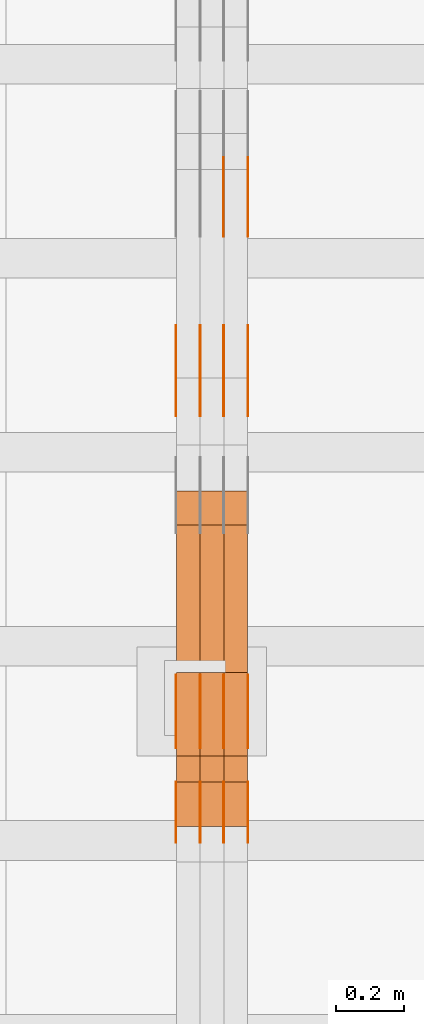
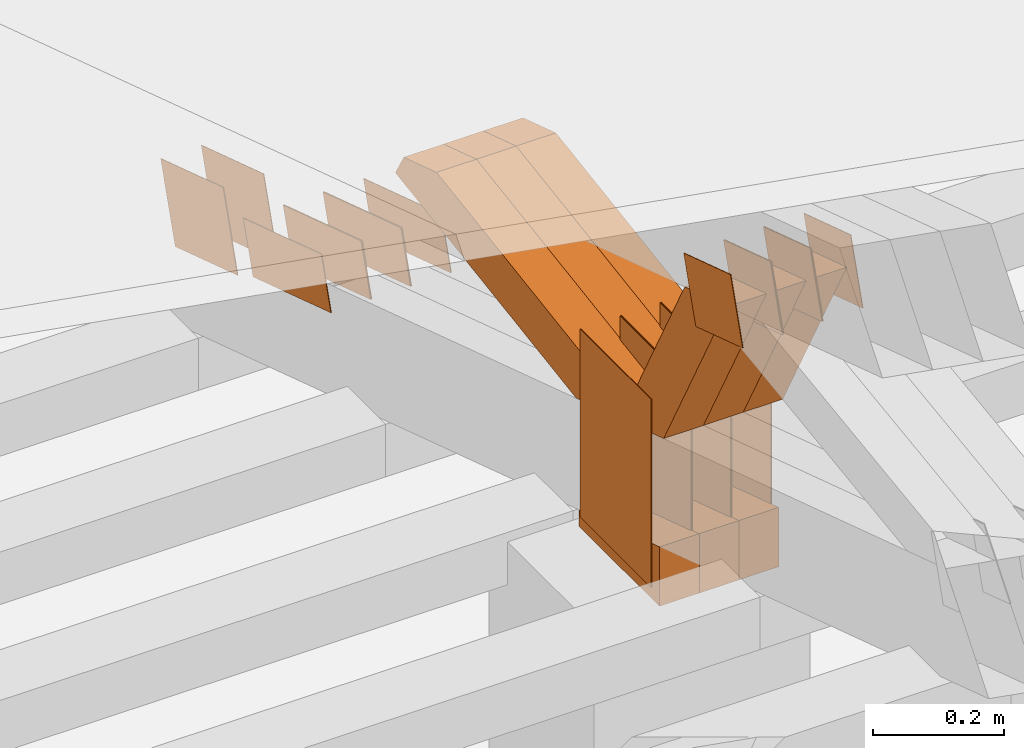
# One storey, part 165 of 385: 29 proxies.
"""IFC2X3 building model written with IfcOpenShell, lengths in millimetres."""

from ifc_helpers import new_model, entity, si_unit, converted_unit, derived_unit, direction, frame, origin, origin_2d_with_axis, place, context, subcontext, project, spatial, polyline, rectangle, outline, extrude, source, transform, mapped, material, type_object, type_shapes, element, save


model = new_model("IFC2X3")

# Units and contexts
model_context = context("Model", 3, precision=0.01, world=origin(), true_north=direction((6.12303176911189e-17, 1.0)))
body_context = subcontext(model_context, "Body", "Model", "MODEL_VIEW")
ifc_project = project(units=[si_unit("LENGTHUNIT", "METRE", prefix="MILLI"), si_unit("AREAUNIT", "SQUARE_METRE"), si_unit("VOLUMEUNIT", "CUBIC_METRE"), converted_unit("PLANEANGLEUNIT", "DEGREE", entity("IfcRatioMeasure", 0.0174532925199433), si_unit("PLANEANGLEUNIT", "RADIAN"), dimensions=[0, 0, 0, 0, 0, 0, 0]), si_unit("MASSUNIT", "GRAM", prefix="KILO"), derived_unit("MASSDENSITYUNIT", [(si_unit("MASSUNIT", "GRAM", prefix="KILO"), 1), (si_unit("LENGTHUNIT", "METRE"), -3)]), si_unit("TIMEUNIT", "SECOND"), si_unit("FREQUENCYUNIT", "HERTZ"), si_unit("THERMODYNAMICTEMPERATUREUNIT", "DEGREE_CELSIUS"), derived_unit("THERMALTRANSMITTANCEUNIT", [(si_unit("MASSUNIT", "GRAM", prefix="KILO"), 1), (si_unit("THERMODYNAMICTEMPERATUREUNIT", "KELVIN"), -1), (si_unit("TIMEUNIT", "SECOND"), -3)]), derived_unit("VOLUMETRICFLOWRATEUNIT", [(si_unit("LENGTHUNIT", "METRE"), 3), (si_unit("TIMEUNIT", "SECOND"), -1)]), si_unit("ELECTRICCURRENTUNIT", "AMPERE"), si_unit("ELECTRICVOLTAGEUNIT", "VOLT"), si_unit("POWERUNIT", "WATT"), si_unit("FORCEUNIT", "NEWTON", prefix="KILO"), si_unit("ILLUMINANCEUNIT", "LUX"), si_unit("LUMINOUSFLUXUNIT", "LUMEN"), si_unit("LUMINOUSINTENSITYUNIT", "CANDELA"), derived_unit("USERDEFINED", [(si_unit("MASSUNIT", "GRAM", prefix="KILO"), -1), (si_unit("LENGTHUNIT", "METRE"), -2), (si_unit("TIMEUNIT", "SECOND"), 3), (si_unit("LUMINOUSFLUXUNIT", "LUMEN"), 1)]), derived_unit("LINEARVELOCITYUNIT", [(si_unit("LENGTHUNIT", "METRE"), 1), (si_unit("TIMEUNIT", "SECOND"), -1)]), si_unit("PRESSUREUNIT", "PASCAL"), derived_unit("USERDEFINED", [(si_unit("LENGTHUNIT", "METRE"), -2), (si_unit("MASSUNIT", "GRAM", prefix="KILO"), 1), (si_unit("TIMEUNIT", "SECOND"), -2)])], contexts=[model_context])

# Site, building, storey
site_placement = place(None, origin())
site = spatial("IfcSite", under=ifc_project, at=site_placement, CompositionType="ELEMENT")
building_placement = place(site_placement, origin())
building = spatial("IfcBuilding", under=site, at=building_placement, CompositionType="ELEMENT")
storey_placement = place(building_placement, origin())
storey = spatial("IfcBuildingStorey", under=building, at=storey_placement, Name="Default", CompositionType="ELEMENT", Elevation=0.0)

# Proxies
ifc_material_1 = material(Name="IfcSurfaceStyle #342422")
building_element_proxy_type_1 = type_object("IfcBuildingElementProxyType", PredefinedType="NOTDEFINED", material=ifc_material_1)
shared_shape_1 = source(origin(), body_context, "Body", "SweptSolid", [
    extrude(outline(polyline([(-125.00031378339, -47.9999612158856), (125.000225258022, -47.9999612158856), (124.999811678525, 47.9999612158856), (-124.999723153156, 47.9999612158856), (-125.00031378339, -47.9999612158856)])), frame((125.000225258022, 48.0000091013474, 0.0), z_axis=(0.0, 0.0, 1.0), x_axis=(-1.0, 0.0, 0.0)), (0.0, 0.0, 1.0), 1.3),
])
type_shapes(building_element_proxy_type_1, [shared_shape_1])
proxy_1_placement = place(building_placement, frame((27386.3, 18456.8597683375, 2657.46691321253), z_axis=(-1.0, 0.0, 0.0), x_axis=(0.0, -0.951056516295124, 0.309016994375039)))
element("IfcBuildingElementProxy", 1, at=proxy_1_placement, inside=storey, type_object=building_element_proxy_type_1, material=ifc_material_1, context=body_context, shape_type="MappedRepresentation", body=[
    mapped(shared_shape_1, transform((0.0, 0.0, 0.0), scale=1.0)),
])
ifc_material_2 = material(Name="IfcSurfaceStyle #342365")
building_element_proxy_type_2 = type_object("IfcBuildingElementProxyType", PredefinedType="NOTDEFINED", material=ifc_material_2)
shared_shape_2 = source(origin(), body_context, "Body", "SweptSolid", [
    extrude(outline(polyline([(-125.00031378339, -47.9999612158856), (125.000225258022, -47.9999612158856), (124.999811678525, 47.9999612158856), (-124.999723153156, 47.9999612158856), (-125.00031378339, -47.9999612158856)])), frame((125.000225258022, 48.0000091013474, 0.0), z_axis=(0.0, 0.0, 1.0), x_axis=(-1.0, 0.0, 0.0)), (0.0, 0.0, 1.0), 1.3),
])
type_shapes(building_element_proxy_type_2, [shared_shape_2])
proxy_2_placement = place(building_placement, frame((27315.0, 18456.8597683375, 2657.46691321253), z_axis=(-1.0, 0.0, 0.0), x_axis=(0.0, -0.951056516295124, 0.309016994375039)))
element("IfcBuildingElementProxy", 2, at=proxy_2_placement, inside=storey, type_object=building_element_proxy_type_2, material=ifc_material_2, context=body_context, shape_type="MappedRepresentation", body=[
    mapped(shared_shape_2, transform((0.0, 0.0, 0.0), scale=1.0)),
])
ifc_material_3 = material(Name="IfcSurfaceStyle #342308")
building_element_proxy_type_3 = type_object("IfcBuildingElementProxyType", PredefinedType="NOTDEFINED", material=ifc_material_3)
shared_shape_3 = source(origin(), body_context, "Body", "SweptSolid", [
    extrude(outline(polyline([(-125.00031378339, -47.9999612158856), (125.000225258022, -47.9999612158856), (124.999811678525, 47.9999612158856), (-124.999723153156, 47.9999612158856), (-125.00031378339, -47.9999612158856)])), frame((125.000225258022, 48.0000091013474, 0.0), z_axis=(0.0, 0.0, 1.0), x_axis=(-1.0, 0.0, 0.0)), (0.0, 0.0, 1.0), 1.3),
])
type_shapes(building_element_proxy_type_3, [shared_shape_3])
proxy_3_placement = place(building_placement, frame((27316.3, 18456.8597683375, 2657.46691321253), z_axis=(-1.0, 0.0, 0.0), x_axis=(0.0, -0.951056516295124, 0.309016994375039)))
element("IfcBuildingElementProxy", 3, at=proxy_3_placement, inside=storey, type_object=building_element_proxy_type_3, material=ifc_material_3, context=body_context, shape_type="MappedRepresentation", body=[
    mapped(shared_shape_3, transform((0.0, 0.0, 0.0), scale=1.0)),
])
ifc_material_4 = material(Name="IfcSurfaceStyle #342251")
building_element_proxy_type_4 = type_object("IfcBuildingElementProxyType", PredefinedType="NOTDEFINED", material=ifc_material_4)
shared_shape_4 = source(origin(), body_context, "Body", "SweptSolid", [
    extrude(outline(polyline([(-125.00031378339, -47.9999612158856), (125.000225258022, -47.9999612158856), (124.999811678525, 47.9999612158856), (-124.999723153156, 47.9999612158856), (-125.00031378339, -47.9999612158856)])), frame((125.000225258022, 48.0000091013474, 0.0), z_axis=(0.0, 0.0, 1.0), x_axis=(-1.0, 0.0, 0.0)), (0.0, 0.0, 1.0), 1.29999999999998),
])
type_shapes(building_element_proxy_type_4, [shared_shape_4])
proxy_4_placement = place(building_placement, frame((27245.0, 18456.8597683375, 2657.46691321253), z_axis=(-1.0, 0.0, 0.0), x_axis=(0.0, -0.951056516295124, 0.309016994375039)))
element("IfcBuildingElementProxy", 4, at=proxy_4_placement, inside=storey, type_object=building_element_proxy_type_4, material=ifc_material_4, context=body_context, shape_type="MappedRepresentation", body=[
    mapped(shared_shape_4, transform((0.0, 0.0, 0.0), scale=1.0)),
])
ifc_material_5 = material(Name="IfcSurfaceStyle #342194")
building_element_proxy_type_5 = type_object("IfcBuildingElementProxyType", PredefinedType="NOTDEFINED", material=ifc_material_5)
shared_shape_5 = source(origin(), body_context, "Body", "SweptSolid", [
    extrude(outline(polyline([(-125.00031378339, -47.9999612158856), (125.000225258022, -47.9999612158856), (124.999811678525, 47.9999612158856), (-124.999723153156, 47.9999612158856), (-125.00031378339, -47.9999612158856)])), frame((125.000225258022, 48.0000091013474, 0.0), z_axis=(0.0, 0.0, 1.0), x_axis=(-1.0, 0.0, 0.0)), (0.0, 0.0, 1.0), 1.29999999999998),
])
type_shapes(building_element_proxy_type_5, [shared_shape_5])
proxy_5_placement = place(building_placement, frame((27246.3, 18456.8597683375, 2657.46691321253), z_axis=(-1.0, 0.0, 0.0), x_axis=(0.0, -0.951056516295124, 0.309016994375039)))
element("IfcBuildingElementProxy", 5, at=proxy_5_placement, inside=storey, type_object=building_element_proxy_type_5, material=ifc_material_5, context=body_context, shape_type="MappedRepresentation", body=[
    mapped(shared_shape_5, transform((0.0, 0.0, 0.0), scale=1.0)),
])
ifc_material_6 = material(Name="IfcSurfaceStyle #342137")
building_element_proxy_type_6 = type_object("IfcBuildingElementProxyType", PredefinedType="NOTDEFINED", material=ifc_material_6)
shared_shape_6 = source(origin(), body_context, "Body", "SweptSolid", [
    extrude(outline(polyline([(-125.00031378339, -47.9999612158856), (125.000225258022, -47.9999612158856), (124.999811678525, 47.9999612158856), (-124.999723153156, 47.9999612158856), (-125.00031378339, -47.9999612158856)])), frame((125.000225258022, 48.0000091013474, 0.0), z_axis=(0.0, 0.0, 1.0), x_axis=(-1.0, 0.0, 0.0)), (0.0, 0.0, 1.0), 1.29999999999998),
])
type_shapes(building_element_proxy_type_6, [shared_shape_6])
proxy_6_placement = place(building_placement, frame((27175.0, 18456.8597683375, 2657.46691321253), z_axis=(-1.0, 0.0, 0.0), x_axis=(0.0, -0.951056516295124, 0.309016994375039)))
element("IfcBuildingElementProxy", 6, at=proxy_6_placement, inside=storey, type_object=building_element_proxy_type_6, material=ifc_material_6, context=body_context, shape_type="MappedRepresentation", body=[
    mapped(shared_shape_6, transform((0.0, 0.0, 0.0), scale=1.0)),
])
ifc_material_7 = material(Name="IfcSurfaceStyle #340712")
building_element_proxy_type_7 = type_object("IfcBuildingElementProxyType", PredefinedType="NOTDEFINED", material=ifc_material_7)
shared_shape_7 = source(origin(), body_context, "Body", "SweptSolid", [
    extrude(outline(polyline([(-99.999796294464, -72.0000050220467), (99.9998768370438, -72.0000050220467), (100.000260677528, 72.0000050220467), (-100.000341220108, 72.0000050220467), (-99.999796294464, -72.0000050220467)])), frame((100.000260677528, 72.0000050220467, 0.0), z_axis=(0.0, 0.0, 1.0), x_axis=(-1.0, 0.0, 0.0)), (0.0, 0.0, 1.0), 1.3),
])
type_shapes(building_element_proxy_type_7, [shared_shape_7])
proxy_7_placement = place(building_placement, frame((27386.3, 18936.3876569477, 2373.90613192527), z_axis=(-1.0, 0.0, 0.0), x_axis=(0.0, -0.951056516295124, 0.309016994375039)))
element("IfcBuildingElementProxy", 7, at=proxy_7_placement, inside=storey, type_object=building_element_proxy_type_7, material=ifc_material_7, context=body_context, shape_type="MappedRepresentation", body=[
    mapped(shared_shape_7, transform((0.0, 0.0, 0.0), scale=1.0)),
])
ifc_material_8 = material(Name="IfcSurfaceStyle #340655")
building_element_proxy_type_8 = type_object("IfcBuildingElementProxyType", PredefinedType="NOTDEFINED", material=ifc_material_8)
shared_shape_8 = source(origin(), body_context, "Body", "SweptSolid", [
    extrude(outline(polyline([(-99.999796294464, -72.0000050220467), (99.9998768370438, -72.0000050220467), (100.000260677528, 72.0000050220467), (-100.000341220108, 72.0000050220467), (-99.999796294464, -72.0000050220467)])), frame((100.000260677528, 72.0000050220467, 0.0), z_axis=(0.0, 0.0, 1.0), x_axis=(-1.0, 0.0, 0.0)), (0.0, 0.0, 1.0), 1.3),
])
type_shapes(building_element_proxy_type_8, [shared_shape_8])
proxy_8_placement = place(building_placement, frame((27315.0, 18936.3876569477, 2373.90613192527), z_axis=(-1.0, 0.0, 0.0), x_axis=(0.0, -0.951056516295124, 0.309016994375039)))
element("IfcBuildingElementProxy", 8, at=proxy_8_placement, inside=storey, type_object=building_element_proxy_type_8, material=ifc_material_8, context=body_context, shape_type="MappedRepresentation", body=[
    mapped(shared_shape_8, transform((0.0, 0.0, 0.0), scale=1.0)),
])
ifc_material_9 = material(Name="IfcSurfaceStyle #340370")
building_element_proxy_type_9 = type_object("IfcBuildingElementProxyType", PredefinedType="NOTDEFINED", material=ifc_material_9)
shared_shape_9 = source(origin(), body_context, "Body", "SweptSolid", [
    extrude(rectangle(XDim=350.0, YDim=215.999999999984, at=origin_2d_with_axis()), frame((175.0, 108.0, 0.0), z_axis=(0.0, 0.0, 1.0), x_axis=(-1.0, 0.0, 0.0)), (0.0, 0.0, 1.0), 1.29999999999999),
])
type_shapes(building_element_proxy_type_9, [shared_shape_9])
proxy_9_placement = place(building_placement, frame((27386.3, 17459.2939453125, 3165.36425781251), z_axis=(-1.0, 0.0, 0.0), x_axis=(0.0, 0.0, -1.0)))
element("IfcBuildingElementProxy", 9, at=proxy_9_placement, inside=storey, type_object=building_element_proxy_type_9, material=ifc_material_9, context=body_context, shape_type="MappedRepresentation", body=[
    mapped(shared_shape_9, transform((0.0, 0.0, 0.0), scale=1.0)),
])
ifc_material_10 = material(Name="IfcSurfaceStyle #340313")
building_element_proxy_type_10 = type_object("IfcBuildingElementProxyType", PredefinedType="NOTDEFINED", material=ifc_material_10)
shared_shape_10 = source(origin(), body_context, "Body", "SweptSolid", [
    extrude(rectangle(XDim=350.0, YDim=215.999999999984, at=origin_2d_with_axis()), frame((175.0, 108.0, 0.0), z_axis=(0.0, 0.0, 1.0), x_axis=(-1.0, 0.0, 0.0)), (0.0, 0.0, 1.0), 1.29999999999999),
])
type_shapes(building_element_proxy_type_10, [shared_shape_10])
proxy_10_placement = place(building_placement, frame((27315.0, 17459.2939453125, 3165.36425781251), z_axis=(-1.0, 0.0, 0.0), x_axis=(0.0, 0.0, -1.0)))
element("IfcBuildingElementProxy", 10, at=proxy_10_placement, inside=storey, type_object=building_element_proxy_type_10, material=ifc_material_10, context=body_context, shape_type="MappedRepresentation", body=[
    mapped(shared_shape_10, transform((0.0, 0.0, 0.0), scale=1.0)),
])
ifc_material_11 = material(Name="IfcSurfaceStyle #340256")
building_element_proxy_type_11 = type_object("IfcBuildingElementProxyType", PredefinedType="NOTDEFINED", material=ifc_material_11)
shared_shape_11 = source(origin(), body_context, "Body", "SweptSolid", [
    extrude(rectangle(XDim=350.0, YDim=215.999999999984, at=origin_2d_with_axis()), frame((175.0, 108.0, 0.0), z_axis=(0.0, 0.0, 1.0), x_axis=(-1.0, 0.0, 0.0)), (0.0, 0.0, 1.0), 1.29999999999999),
])
type_shapes(building_element_proxy_type_11, [shared_shape_11])
proxy_11_placement = place(building_placement, frame((27316.3, 17459.2939453125, 3165.36425781251), z_axis=(-1.0, 0.0, 0.0), x_axis=(0.0, 0.0, -1.0)))
element("IfcBuildingElementProxy", 11, at=proxy_11_placement, inside=storey, type_object=building_element_proxy_type_11, material=ifc_material_11, context=body_context, shape_type="MappedRepresentation", body=[
    mapped(shared_shape_11, transform((0.0, 0.0, 0.0), scale=1.0)),
])
ifc_material_12 = material(Name="IfcSurfaceStyle #340199")
building_element_proxy_type_12 = type_object("IfcBuildingElementProxyType", PredefinedType="NOTDEFINED", material=ifc_material_12)
shared_shape_12 = source(origin(), body_context, "Body", "SweptSolid", [
    extrude(rectangle(XDim=350.0, YDim=215.999999999984, at=origin_2d_with_axis()), frame((175.0, 108.0, 0.0), z_axis=(0.0, 0.0, 1.0), x_axis=(-1.0, 0.0, 0.0)), (0.0, 0.0, 1.0), 1.29999999999998),
])
type_shapes(building_element_proxy_type_12, [shared_shape_12])
proxy_12_placement = place(building_placement, frame((27245.0, 17459.2939453125, 3165.36425781251), z_axis=(-1.0, 0.0, 0.0), x_axis=(0.0, 0.0, -1.0)))
element("IfcBuildingElementProxy", 12, at=proxy_12_placement, inside=storey, type_object=building_element_proxy_type_12, material=ifc_material_12, context=body_context, shape_type="MappedRepresentation", body=[
    mapped(shared_shape_12, transform((0.0, 0.0, 0.0), scale=1.0)),
])
ifc_material_13 = material(Name="IfcSurfaceStyle #340142")
building_element_proxy_type_13 = type_object("IfcBuildingElementProxyType", PredefinedType="NOTDEFINED", material=ifc_material_13)
shared_shape_13 = source(origin(), body_context, "Body", "SweptSolid", [
    extrude(rectangle(XDim=350.0, YDim=215.999999999984, at=origin_2d_with_axis()), frame((175.0, 108.0, 0.0), z_axis=(0.0, 0.0, 1.0), x_axis=(-1.0, 0.0, 0.0)), (0.0, 0.0, 1.0), 1.29999999999998),
])
type_shapes(building_element_proxy_type_13, [shared_shape_13])
proxy_13_placement = place(building_placement, frame((27246.3, 17459.2939453125, 3165.36425781251), z_axis=(-1.0, 0.0, 0.0), x_axis=(0.0, 0.0, -1.0)))
element("IfcBuildingElementProxy", 13, at=proxy_13_placement, inside=storey, type_object=building_element_proxy_type_13, material=ifc_material_13, context=body_context, shape_type="MappedRepresentation", body=[
    mapped(shared_shape_13, transform((0.0, 0.0, 0.0), scale=1.0)),
])
ifc_material_14 = material(Name="IfcSurfaceStyle #340085")
building_element_proxy_type_14 = type_object("IfcBuildingElementProxyType", PredefinedType="NOTDEFINED", material=ifc_material_14)
shared_shape_14 = source(origin(), body_context, "Body", "SweptSolid", [
    extrude(rectangle(XDim=350.0, YDim=215.999999999984, at=origin_2d_with_axis()), frame((175.0, 108.0, 0.0), z_axis=(0.0, 0.0, 1.0), x_axis=(-1.0, 0.0, 0.0)), (0.0, 0.0, 1.0), 1.29999999999998),
])
type_shapes(building_element_proxy_type_14, [shared_shape_14])
proxy_14_placement = place(building_placement, frame((27175.0, 17459.2939453125, 3165.36425781251), z_axis=(-1.0, 0.0, 0.0), x_axis=(0.0, 0.0, -1.0)))
element("IfcBuildingElementProxy", 14, at=proxy_14_placement, inside=storey, type_object=building_element_proxy_type_14, material=ifc_material_14, context=body_context, shape_type="MappedRepresentation", body=[
    mapped(shared_shape_14, transform((0.0, 0.0, 0.0), scale=1.0)),
])
ifc_material_15 = material(Name="IfcSurfaceStyle #336950")
building_element_proxy_type_15 = type_object("IfcBuildingElementProxyType", PredefinedType="NOTDEFINED", material=ifc_material_15)
shared_shape_15 = source(origin(), body_context, "Body", "SweptSolid", [
    extrude(outline(polyline([(-74.9998605591058, -59.9999264677524), (74.999875428623, -59.9999264677524), (74.9998605591068, 59.9999264677524), (-74.9998754286239, 59.9999264677524), (-74.9998605591058, -59.9999264677524)])), frame((75.0002460484325, 60.0000016373508, 0.0), z_axis=(0.0, 0.0, 1.0), x_axis=(-1.0, 0.0, 0.0)), (0.0, 0.0, 1.0), 1.3),
])
type_shapes(building_element_proxy_type_15, [shared_shape_15])
proxy_15_placement = place(building_placement, frame((27386.3, 17107.0599369346, 3383.82825001787), z_axis=(-1.0, 0.0, 0.0), x_axis=(0.0, -0.951056516295154, 0.309016994374948)))
element("IfcBuildingElementProxy", 15, at=proxy_15_placement, inside=storey, type_object=building_element_proxy_type_15, material=ifc_material_15, context=body_context, shape_type="MappedRepresentation", body=[
    mapped(shared_shape_15, transform((0.0, 0.0, 0.0), scale=1.0)),
])
ifc_material_16 = material(Name="IfcSurfaceStyle #336893")
building_element_proxy_type_16 = type_object("IfcBuildingElementProxyType", PredefinedType="NOTDEFINED", material=ifc_material_16)
shared_shape_16 = source(origin(), body_context, "Body", "SweptSolid", [
    extrude(outline(polyline([(-74.9998605591058, -59.9999264677524), (74.999875428623, -59.9999264677524), (74.9998605591068, 59.9999264677524), (-74.9998754286239, 59.9999264677524), (-74.9998605591058, -59.9999264677524)])), frame((75.0002460484325, 60.0000016373508, 0.0), z_axis=(0.0, 0.0, 1.0), x_axis=(-1.0, 0.0, 0.0)), (0.0, 0.0, 1.0), 1.3),
])
type_shapes(building_element_proxy_type_16, [shared_shape_16])
proxy_16_placement = place(building_placement, frame((27315.0, 17107.0599369346, 3383.82825001787), z_axis=(-1.0, 0.0, 0.0), x_axis=(0.0, -0.951056516295154, 0.309016994374948)))
element("IfcBuildingElementProxy", 16, at=proxy_16_placement, inside=storey, type_object=building_element_proxy_type_16, material=ifc_material_16, context=body_context, shape_type="MappedRepresentation", body=[
    mapped(shared_shape_16, transform((0.0, 0.0, 0.0), scale=1.0)),
])
ifc_material_17 = material(Name="IfcSurfaceStyle #336836")
building_element_proxy_type_17 = type_object("IfcBuildingElementProxyType", PredefinedType="NOTDEFINED", material=ifc_material_17)
shared_shape_17 = source(origin(), body_context, "Body", "SweptSolid", [
    extrude(outline(polyline([(-74.9998605591058, -59.9999264677524), (74.999875428623, -59.9999264677524), (74.9998605591068, 59.9999264677524), (-74.9998754286239, 59.9999264677524), (-74.9998605591058, -59.9999264677524)])), frame((75.0002460484325, 60.0000016373508, 0.0), z_axis=(0.0, 0.0, 1.0), x_axis=(-1.0, 0.0, 0.0)), (0.0, 0.0, 1.0), 1.3),
])
type_shapes(building_element_proxy_type_17, [shared_shape_17])
proxy_17_placement = place(building_placement, frame((27316.3, 17107.0599369346, 3383.82825001787), z_axis=(-1.0, 0.0, 0.0), x_axis=(0.0, -0.951056516295154, 0.309016994374948)))
element("IfcBuildingElementProxy", 17, at=proxy_17_placement, inside=storey, type_object=building_element_proxy_type_17, material=ifc_material_17, context=body_context, shape_type="MappedRepresentation", body=[
    mapped(shared_shape_17, transform((0.0, 0.0, 0.0), scale=1.0)),
])
ifc_material_18 = material(Name="IfcSurfaceStyle #336779")
building_element_proxy_type_18 = type_object("IfcBuildingElementProxyType", PredefinedType="NOTDEFINED", material=ifc_material_18)
shared_shape_18 = source(origin(), body_context, "Body", "SweptSolid", [
    extrude(outline(polyline([(-74.9998605591058, -59.9999264677524), (74.999875428623, -59.9999264677524), (74.9998605591068, 59.9999264677524), (-74.9998754286239, 59.9999264677524), (-74.9998605591058, -59.9999264677524)])), frame((75.0002460484325, 60.0000016373508, 0.0), z_axis=(0.0, 0.0, 1.0), x_axis=(-1.0, 0.0, 0.0)), (0.0, 0.0, 1.0), 1.29999999999999),
])
type_shapes(building_element_proxy_type_18, [shared_shape_18])
proxy_18_placement = place(building_placement, frame((27245.0, 17107.0599369346, 3383.82825001787), z_axis=(-1.0, 0.0, 0.0), x_axis=(0.0, -0.951056516295154, 0.309016994374948)))
element("IfcBuildingElementProxy", 18, at=proxy_18_placement, inside=storey, type_object=building_element_proxy_type_18, material=ifc_material_18, context=body_context, shape_type="MappedRepresentation", body=[
    mapped(shared_shape_18, transform((0.0, 0.0, 0.0), scale=1.0)),
])
ifc_material_19 = material(Name="IfcSurfaceStyle #336722")
building_element_proxy_type_19 = type_object("IfcBuildingElementProxyType", PredefinedType="NOTDEFINED", material=ifc_material_19)
shared_shape_19 = source(origin(), body_context, "Body", "SweptSolid", [
    extrude(outline(polyline([(-74.9998605591058, -59.9999264677524), (74.999875428623, -59.9999264677524), (74.9998605591068, 59.9999264677524), (-74.9998754286239, 59.9999264677524), (-74.9998605591058, -59.9999264677524)])), frame((75.0002460484325, 60.0000016373508, 0.0), z_axis=(0.0, 0.0, 1.0), x_axis=(-1.0, 0.0, 0.0)), (0.0, 0.0, 1.0), 1.29999999999999),
])
type_shapes(building_element_proxy_type_19, [shared_shape_19])
proxy_19_placement = place(building_placement, frame((27246.3, 17107.0599369346, 3383.82825001787), z_axis=(-1.0, 0.0, 0.0), x_axis=(0.0, -0.951056516295154, 0.309016994374948)))
element("IfcBuildingElementProxy", 19, at=proxy_19_placement, inside=storey, type_object=building_element_proxy_type_19, material=ifc_material_19, context=body_context, shape_type="MappedRepresentation", body=[
    mapped(shared_shape_19, transform((0.0, 0.0, 0.0), scale=1.0)),
])
ifc_material_20 = material(Name="IfcSurfaceStyle #336665")
building_element_proxy_type_20 = type_object("IfcBuildingElementProxyType", PredefinedType="NOTDEFINED", material=ifc_material_20)
shared_shape_20 = source(origin(), body_context, "Body", "SweptSolid", [
    extrude(outline(polyline([(-74.9998605591058, -59.9999264677524), (74.999875428623, -59.9999264677524), (74.9998605591068, 59.9999264677524), (-74.9998754286239, 59.9999264677524), (-74.9998605591058, -59.9999264677524)])), frame((75.0002460484325, 60.0000016373508, 0.0), z_axis=(0.0, 0.0, 1.0), x_axis=(-1.0, 0.0, 0.0)), (0.0, 0.0, 1.0), 1.29999999999999),
])
type_shapes(building_element_proxy_type_20, [shared_shape_20])
proxy_20_placement = place(building_placement, frame((27175.0, 17107.0599369346, 3383.82825001787), z_axis=(-1.0, 0.0, 0.0), x_axis=(0.0, -0.951056516295154, 0.309016994374948)))
element("IfcBuildingElementProxy", 20, at=proxy_20_placement, inside=storey, type_object=building_element_proxy_type_20, material=ifc_material_20, context=body_context, shape_type="MappedRepresentation", body=[
    mapped(shared_shape_20, transform((0.0, 0.0, 0.0), scale=1.0)),
])
ifc_material_21 = material(Name="IfcSurfaceStyle #328661")
building_element_proxy_type_21 = type_object("IfcBuildingElementProxyType", Name="T1-E1 328659", PredefinedType="NOTDEFINED", material=ifc_material_21)
shared_shape_21 = source(origin(), body_context, "Body", "SweptSolid", [
    extrude(outline(polyline([(4.4675903320374, -122.500000000001), (35.3350219726624, -122.500000000001), (35.3350219726501, 122.500000000001), (-75.1376342773499, 122.500000000001), (4.4675903320374, -122.500000000001)])), frame((35.3350219726624, 122.50000005215, 0.0), z_axis=(0.0, 0.0, 1.0), x_axis=(-1.0, 0.0, 0.0)), (0.0, 0.0, 1.0), 70.0),
])
type_shapes(building_element_proxy_type_21, [shared_shape_21])
proxy_21_placement = place(building_placement, frame((27385.0, 17220.0, 2794.30932617186), z_axis=(-1.0, 0.0, 0.0), x_axis=(0.0, 0.0, 1.0)))
element("IfcBuildingElementProxy", 21, at=proxy_21_placement, inside=storey, type_object=building_element_proxy_type_21, material=ifc_material_21, Name="T1-E1", context=body_context, shape_type="MappedRepresentation", body=[
    mapped(shared_shape_21, transform((0.0, 0.0, 0.0), scale=1.0)),
])
ifc_material_22 = material(Name="IfcSurfaceStyle #328604")
building_element_proxy_type_22 = type_object("IfcBuildingElementProxyType", Name="T1-E1 328602", PredefinedType="NOTDEFINED", material=ifc_material_22)
shared_shape_22 = source(origin(), body_context, "Body", "SweptSolid", [
    extrude(outline(polyline([(4.4675903320374, -122.500000000001), (35.3350219726624, -122.500000000001), (35.3350219726501, 122.500000000001), (-75.1376342773499, 122.500000000001), (4.4675903320374, -122.500000000001)])), frame((35.3350219726624, 122.50000005215, 0.0), z_axis=(0.0, 0.0, 1.0), x_axis=(-1.0, 0.0, 0.0)), (0.0, 0.0, 1.0), 70.0),
])
type_shapes(building_element_proxy_type_22, [shared_shape_22])
proxy_22_placement = place(building_placement, frame((27315.0, 17220.0, 2794.30932617186), z_axis=(-1.0, 0.0, 0.0), x_axis=(0.0, 0.0, 1.0)))
element("IfcBuildingElementProxy", 22, at=proxy_22_placement, inside=storey, type_object=building_element_proxy_type_22, material=ifc_material_22, Name="T1-E1", context=body_context, shape_type="MappedRepresentation", body=[
    mapped(shared_shape_22, transform((0.0, 0.0, 0.0), scale=1.0)),
])
ifc_material_23 = material(Name="IfcSurfaceStyle #328547")
building_element_proxy_type_23 = type_object("IfcBuildingElementProxyType", Name="T1-E1 328545", PredefinedType="NOTDEFINED", material=ifc_material_23)
shared_shape_23 = source(origin(), body_context, "Body", "SweptSolid", [
    extrude(outline(polyline([(4.4675903320374, -122.500000000001), (35.3350219726624, -122.500000000001), (35.3350219726501, 122.500000000001), (-75.1376342773499, 122.500000000001), (4.4675903320374, -122.500000000001)])), frame((35.3350219726624, 122.50000005215, 0.0), z_axis=(0.0, 0.0, 1.0), x_axis=(-1.0, 0.0, 0.0)), (0.0, 0.0, 1.0), 70.0),
])
type_shapes(building_element_proxy_type_23, [shared_shape_23])
proxy_23_placement = place(building_placement, frame((27245.0, 17220.0, 2794.30932617186), z_axis=(-1.0, 0.0, 0.0), x_axis=(0.0, 0.0, 1.0)))
element("IfcBuildingElementProxy", 23, at=proxy_23_placement, inside=storey, type_object=building_element_proxy_type_23, material=ifc_material_23, Name="T1-E1", context=body_context, shape_type="MappedRepresentation", body=[
    mapped(shared_shape_23, transform((0.0, 0.0, 0.0), scale=1.0)),
])
ifc_material_24 = material(Name="IfcSurfaceStyle #326906")
building_element_proxy_type_24 = type_object("IfcBuildingElementProxyType", Name="T1-W39 326904", PredefinedType="NOTDEFINED", material=ifc_material_24)
shared_shape_24 = source(origin(), body_context, "Body", "SweptSolid", [
    extrude(outline(polyline([(-191.519946663886, -47.499928106579), (188.32936223763, -47.499928106579), (171.597440144109, 0.000249483340993841), (122.102882529753, 47.4998033649085), (-290.509738247605, 47.4998033649085), (-191.519946663886, -47.499928106579)])), frame((188.329593252001, 47.499957247623, 0.0), z_axis=(0.0, 0.0, 1.0), x_axis=(-1.0, 0.0, 0.0)), (0.0, 0.0, 1.0), 70.0),
])
type_shapes(building_element_proxy_type_24, [shared_shape_24])
proxy_24_placement = place(building_placement, frame((27385.0, 17238.5876916597, 3055.56121424762), z_axis=(-1.0, 0.0, 0.0), x_axis=(0.0, -0.472216932390777, 0.881482370080902)))
element("IfcBuildingElementProxy", 24, at=proxy_24_placement, inside=storey, type_object=building_element_proxy_type_24, material=ifc_material_24, Name="T1-W39", context=body_context, shape_type="MappedRepresentation", body=[
    mapped(shared_shape_24, transform((0.0, 0.0, 0.0), scale=1.0)),
])
ifc_material_25 = material(Name="IfcSurfaceStyle #326840")
building_element_proxy_type_25 = type_object("IfcBuildingElementProxyType", Name="T1-W39 326838", PredefinedType="NOTDEFINED", material=ifc_material_25)
shared_shape_25 = source(origin(), body_context, "Body", "SweptSolid", [
    extrude(outline(polyline([(-191.519946663886, -47.499928106579), (188.32936223763, -47.499928106579), (171.597440144109, 0.000249483340993841), (122.102882529753, 47.4998033649085), (-290.509738247605, 47.4998033649085), (-191.519946663886, -47.499928106579)])), frame((188.329593252001, 47.499957247623, 0.0), z_axis=(0.0, 0.0, 1.0), x_axis=(-1.0, 0.0, 0.0)), (0.0, 0.0, 1.0), 70.0),
])
type_shapes(building_element_proxy_type_25, [shared_shape_25])
proxy_25_placement = place(building_placement, frame((27315.0, 17238.5876916597, 3055.56121424762), z_axis=(-1.0, 0.0, 0.0), x_axis=(0.0, -0.472216932390777, 0.881482370080902)))
element("IfcBuildingElementProxy", 25, at=proxy_25_placement, inside=storey, type_object=building_element_proxy_type_25, material=ifc_material_25, Name="T1-W39", context=body_context, shape_type="MappedRepresentation", body=[
    mapped(shared_shape_25, transform((0.0, 0.0, 0.0), scale=1.0)),
])
ifc_material_26 = material(Name="IfcSurfaceStyle #326774")
building_element_proxy_type_26 = type_object("IfcBuildingElementProxyType", Name="T1-W39 326772", PredefinedType="NOTDEFINED", material=ifc_material_26)
shared_shape_26 = source(origin(), body_context, "Body", "SweptSolid", [
    extrude(outline(polyline([(-191.519946663886, -47.499928106579), (188.32936223763, -47.499928106579), (171.597440144109, 0.000249483340993841), (122.102882529753, 47.4998033649085), (-290.509738247605, 47.4998033649085), (-191.519946663886, -47.499928106579)])), frame((188.329593252001, 47.499957247623, 0.0), z_axis=(0.0, 0.0, 1.0), x_axis=(-1.0, 0.0, 0.0)), (0.0, 0.0, 1.0), 70.0),
])
type_shapes(building_element_proxy_type_26, [shared_shape_26])
proxy_26_placement = place(building_placement, frame((27245.0, 17238.5876916597, 3055.56121424762), z_axis=(-1.0, 0.0, 0.0), x_axis=(0.0, -0.472216932390777, 0.881482370080902)))
element("IfcBuildingElementProxy", 26, at=proxy_26_placement, inside=storey, type_object=building_element_proxy_type_26, material=ifc_material_26, Name="T1-W39", context=body_context, shape_type="MappedRepresentation", body=[
    mapped(shared_shape_26, transform((0.0, 0.0, 0.0), scale=1.0)),
])
ifc_material_27 = material(Name="IfcSurfaceStyle #326510")
building_element_proxy_type_27 = type_object("IfcBuildingElementProxyType", Name="T1-W10 326508", PredefinedType="NOTDEFINED", material=ifc_material_27)
shared_shape_27 = source(origin(), body_context, "Body", "SweptSolid", [
    extrude(outline(polyline([(-459.546036710757, -47.5000436364511), (174.689450869018, -47.5000436364511), (268.831081103959, 0.00011114562912502), (287.286350706789, 47.4999880636365), (-271.260845969009, 47.4999880636366), (-459.546036710757, -47.5000436364511)])), frame((287.286768781132, 47.5001637448091, 0.0), z_axis=(0.0, 0.0, 1.0), x_axis=(-1.0, 0.0, 0.0)), (0.0, 0.0, 1.0), 70.0),
])
type_shapes(building_element_proxy_type_27, [shared_shape_27])
proxy_27_placement = place(building_placement, frame((27385.0, 18025.1410649788, 3112.76453857986), z_axis=(-1.0, 0.0, 0.0), x_axis=(0.0, -0.988299196256916, -0.152527698068035)))
element("IfcBuildingElementProxy", 27, at=proxy_27_placement, inside=storey, type_object=building_element_proxy_type_27, material=ifc_material_27, Name="T1-W10", context=body_context, shape_type="MappedRepresentation", body=[
    mapped(shared_shape_27, transform((0.0, 0.0, 0.0), scale=1.0)),
])
ifc_material_28 = material(Name="IfcSurfaceStyle #326444")
building_element_proxy_type_28 = type_object("IfcBuildingElementProxyType", Name="T1-W10 326442", PredefinedType="NOTDEFINED", material=ifc_material_28)
shared_shape_28 = source(origin(), body_context, "Body", "SweptSolid", [
    extrude(outline(polyline([(-459.546036710757, -47.5000436364511), (174.689450869018, -47.5000436364511), (268.831081103959, 0.00011114562912502), (287.286350706789, 47.4999880636365), (-271.260845969009, 47.4999880636366), (-459.546036710757, -47.5000436364511)])), frame((287.286768781132, 47.5001637448091, 0.0), z_axis=(0.0, 0.0, 1.0), x_axis=(-1.0, 0.0, 0.0)), (0.0, 0.0, 1.0), 70.0),
])
type_shapes(building_element_proxy_type_28, [shared_shape_28])
proxy_28_placement = place(building_placement, frame((27315.0, 18025.1410649788, 3112.76453857986), z_axis=(-1.0, 0.0, 0.0), x_axis=(0.0, -0.988299196256916, -0.152527698068035)))
element("IfcBuildingElementProxy", 28, at=proxy_28_placement, inside=storey, type_object=building_element_proxy_type_28, material=ifc_material_28, Name="T1-W10", context=body_context, shape_type="MappedRepresentation", body=[
    mapped(shared_shape_28, transform((0.0, 0.0, 0.0), scale=1.0)),
])
ifc_material_29 = material(Name="IfcSurfaceStyle #326378")
building_element_proxy_type_29 = type_object("IfcBuildingElementProxyType", Name="T1-W10 326376", PredefinedType="NOTDEFINED", material=ifc_material_29)
shared_shape_29 = source(origin(), body_context, "Body", "SweptSolid", [
    extrude(outline(polyline([(-459.546036710757, -47.5000436364511), (174.689450869018, -47.5000436364511), (268.831081103959, 0.00011114562912502), (287.286350706789, 47.4999880636365), (-271.260845969009, 47.4999880636366), (-459.546036710757, -47.5000436364511)])), frame((287.286768781132, 47.5001637448091, 0.0), z_axis=(0.0, 0.0, 1.0), x_axis=(-1.0, 0.0, 0.0)), (0.0, 0.0, 1.0), 70.0),
])
type_shapes(building_element_proxy_type_29, [shared_shape_29])
proxy_29_placement = place(building_placement, frame((27245.0, 18025.1410649788, 3112.76453857986), z_axis=(-1.0, 0.0, 0.0), x_axis=(0.0, -0.988299196256916, -0.152527698068035)))
element("IfcBuildingElementProxy", 29, at=proxy_29_placement, inside=storey, type_object=building_element_proxy_type_29, material=ifc_material_29, Name="T1-W10", context=body_context, shape_type="MappedRepresentation", body=[
    mapped(shared_shape_29, transform((0.0, 0.0, 0.0), scale=1.0)),
])

save(model, "model.ifc")
